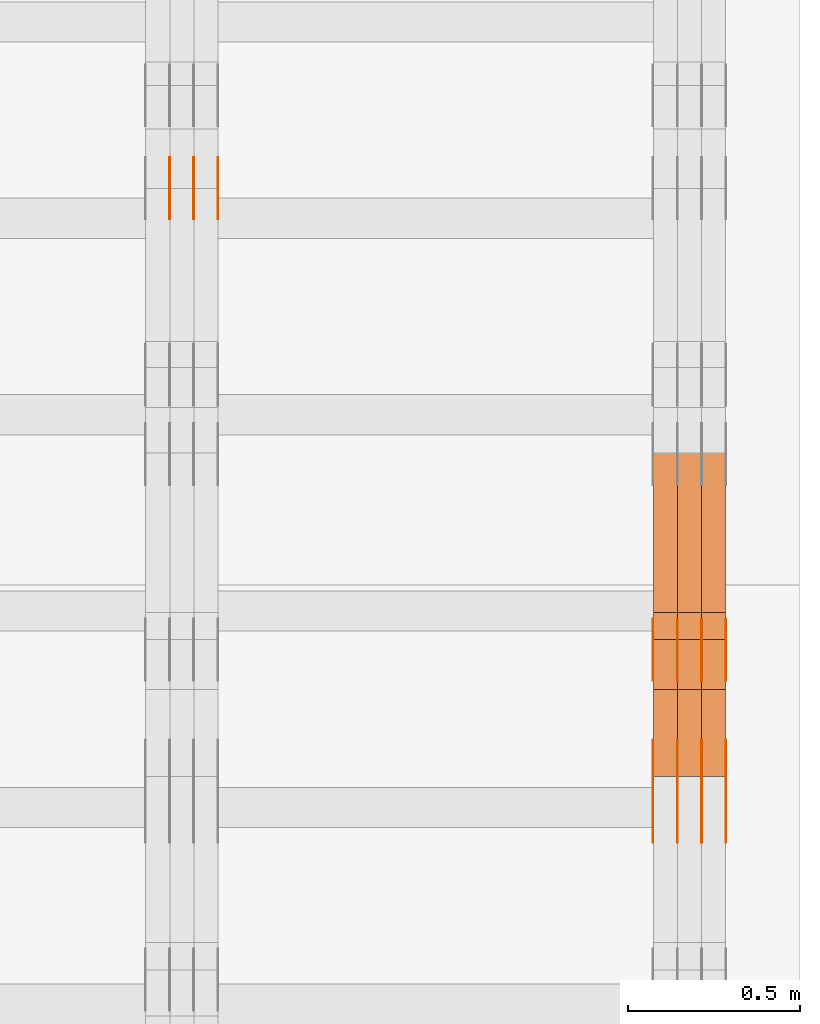
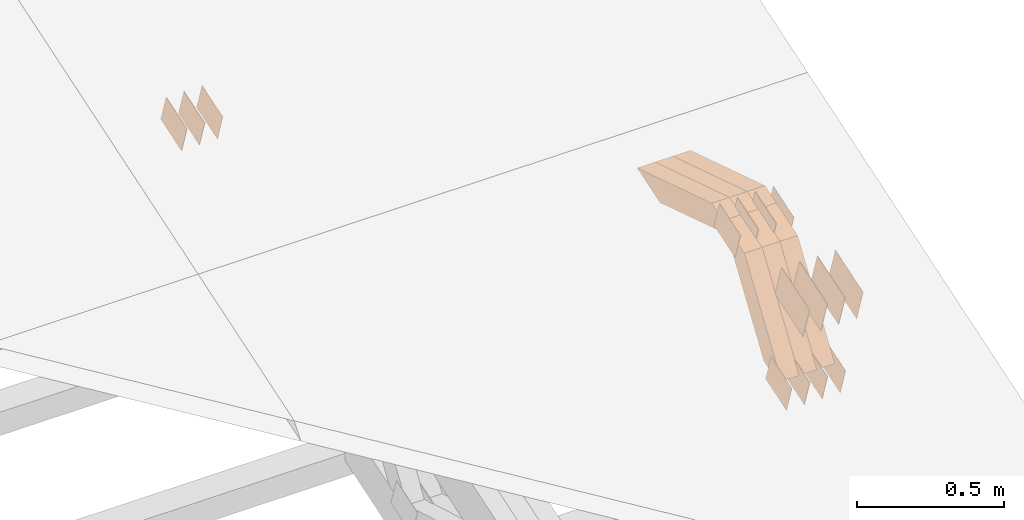
# One storey, part 310 of 385: 29 proxies.
"""IFC2X3 building model written with IfcOpenShell, lengths in millimetres."""

from ifc_helpers import new_model, entity, si_unit, converted_unit, derived_unit, direction, frame, origin, place, context, subcontext, project, spatial, polyline, outline, extrude, source, transform, mapped, material, type_object, type_shapes, element, save


model = new_model("IFC2X3")

# Units and contexts
model_context = context("Model", 3, precision=0.01, world=origin(), true_north=direction((6.12303176911189e-17, 1.0)))
body_context = subcontext(model_context, "Body", "Model", "MODEL_VIEW")
ifc_project = project(units=[si_unit("LENGTHUNIT", "METRE", prefix="MILLI"), si_unit("AREAUNIT", "SQUARE_METRE"), si_unit("VOLUMEUNIT", "CUBIC_METRE"), converted_unit("PLANEANGLEUNIT", "DEGREE", entity("IfcRatioMeasure", 0.0174532925199433), si_unit("PLANEANGLEUNIT", "RADIAN"), dimensions=[0, 0, 0, 0, 0, 0, 0]), si_unit("MASSUNIT", "GRAM", prefix="KILO"), derived_unit("MASSDENSITYUNIT", [(si_unit("MASSUNIT", "GRAM", prefix="KILO"), 1), (si_unit("LENGTHUNIT", "METRE"), -3)]), si_unit("TIMEUNIT", "SECOND"), si_unit("FREQUENCYUNIT", "HERTZ"), si_unit("THERMODYNAMICTEMPERATUREUNIT", "DEGREE_CELSIUS"), derived_unit("THERMALTRANSMITTANCEUNIT", [(si_unit("MASSUNIT", "GRAM", prefix="KILO"), 1), (si_unit("THERMODYNAMICTEMPERATUREUNIT", "KELVIN"), -1), (si_unit("TIMEUNIT", "SECOND"), -3)]), derived_unit("VOLUMETRICFLOWRATEUNIT", [(si_unit("LENGTHUNIT", "METRE"), 3), (si_unit("TIMEUNIT", "SECOND"), -1)]), si_unit("ELECTRICCURRENTUNIT", "AMPERE"), si_unit("ELECTRICVOLTAGEUNIT", "VOLT"), si_unit("POWERUNIT", "WATT"), si_unit("FORCEUNIT", "NEWTON", prefix="KILO"), si_unit("ILLUMINANCEUNIT", "LUX"), si_unit("LUMINOUSFLUXUNIT", "LUMEN"), si_unit("LUMINOUSINTENSITYUNIT", "CANDELA"), derived_unit("USERDEFINED", [(si_unit("MASSUNIT", "GRAM", prefix="KILO"), -1), (si_unit("LENGTHUNIT", "METRE"), -2), (si_unit("TIMEUNIT", "SECOND"), 3), (si_unit("LUMINOUSFLUXUNIT", "LUMEN"), 1)]), derived_unit("LINEARVELOCITYUNIT", [(si_unit("LENGTHUNIT", "METRE"), 1), (si_unit("TIMEUNIT", "SECOND"), -1)]), si_unit("PRESSUREUNIT", "PASCAL"), derived_unit("USERDEFINED", [(si_unit("LENGTHUNIT", "METRE"), -2), (si_unit("MASSUNIT", "GRAM", prefix="KILO"), 1), (si_unit("TIMEUNIT", "SECOND"), -2)])], contexts=[model_context])

# Site, building, storey
site_placement = place(None, origin())
site = spatial("IfcSite", under=ifc_project, at=site_placement, CompositionType="ELEMENT")
building_placement = place(site_placement, origin())
building = spatial("IfcBuilding", under=site, at=building_placement, CompositionType="ELEMENT")
storey_placement = place(building_placement, origin())
storey = spatial("IfcBuildingStorey", under=building, at=storey_placement, Name="Default", CompositionType="ELEMENT", Elevation=0.0)

# Proxies
ifc_material_1 = material(Name="IfcSurfaceStyle #614800")
building_element_proxy_type_1 = type_object("IfcBuildingElementProxyType", PredefinedType="NOTDEFINED", material=ifc_material_1)
shared_shape_1 = source(origin(), body_context, "Body", "SweptSolid", [
    extrude(outline(polyline([(-74.9998707133927, -60.0000596852269), (74.9998841352353, -60.0000596852269), (74.999861282944, 60.0000596852269), (-74.9998747047866, 60.0000596852269), (-74.9998707133927, -60.0000596852269)])), frame((74.9998841352353, 60.0000596852269, 0.0), z_axis=(0.0, 0.0, 1.0), x_axis=(-1.0, 0.0, 0.0)), (0.0, 0.0, 1.0), 1.3),
])
type_shapes(building_element_proxy_type_1, [shared_shape_1])
proxy_1_placement = place(building_placement, frame((49861.3, 5067.4882362875, 826.131473120182), z_axis=(-1.0, 0.0, 0.0), x_axis=(0.0, 0.951056516295124, 0.309016994375039)))
element("IfcBuildingElementProxy", 1, at=proxy_1_placement, inside=storey, type_object=building_element_proxy_type_1, material=ifc_material_1, context=body_context, shape_type="MappedRepresentation", body=[
    mapped(shared_shape_1, transform((0.0, 0.0, 0.0), scale=1.0)),
])
ifc_material_2 = material(Name="IfcSurfaceStyle #614743")
building_element_proxy_type_2 = type_object("IfcBuildingElementProxyType", PredefinedType="NOTDEFINED", material=ifc_material_2)
shared_shape_2 = source(origin(), body_context, "Body", "SweptSolid", [
    extrude(outline(polyline([(-74.9998707133927, -60.0000596852269), (74.9998841352353, -60.0000596852269), (74.999861282944, 60.0000596852269), (-74.9998747047866, 60.0000596852269), (-74.9998707133927, -60.0000596852269)])), frame((74.9998841352353, 60.0000596852269, 0.0), z_axis=(0.0, 0.0, 1.0), x_axis=(-1.0, 0.0, 0.0)), (0.0, 0.0, 1.0), 1.3),
])
type_shapes(building_element_proxy_type_2, [shared_shape_2])
proxy_2_placement = place(building_placement, frame((49790.0, 5067.4882362875, 826.131473120182), z_axis=(-1.0, 0.0, 0.0), x_axis=(0.0, 0.951056516295124, 0.309016994375039)))
element("IfcBuildingElementProxy", 2, at=proxy_2_placement, inside=storey, type_object=building_element_proxy_type_2, material=ifc_material_2, context=body_context, shape_type="MappedRepresentation", body=[
    mapped(shared_shape_2, transform((0.0, 0.0, 0.0), scale=1.0)),
])
ifc_material_3 = material(Name="IfcSurfaceStyle #614686")
building_element_proxy_type_3 = type_object("IfcBuildingElementProxyType", PredefinedType="NOTDEFINED", material=ifc_material_3)
shared_shape_3 = source(origin(), body_context, "Body", "SweptSolid", [
    extrude(outline(polyline([(-74.9998707133927, -60.0000596852269), (74.9998841352353, -60.0000596852269), (74.999861282944, 60.0000596852269), (-74.9998747047866, 60.0000596852269), (-74.9998707133927, -60.0000596852269)])), frame((74.9998841352353, 60.0000596852269, 0.0), z_axis=(0.0, 0.0, 1.0), x_axis=(-1.0, 0.0, 0.0)), (0.0, 0.0, 1.0), 1.3),
])
type_shapes(building_element_proxy_type_3, [shared_shape_3])
proxy_3_placement = place(building_placement, frame((49791.3, 5067.4882362875, 826.131473120182), z_axis=(-1.0, 0.0, 0.0), x_axis=(0.0, 0.951056516295124, 0.309016994375039)))
element("IfcBuildingElementProxy", 3, at=proxy_3_placement, inside=storey, type_object=building_element_proxy_type_3, material=ifc_material_3, context=body_context, shape_type="MappedRepresentation", body=[
    mapped(shared_shape_3, transform((0.0, 0.0, 0.0), scale=1.0)),
])
ifc_material_4 = material(Name="IfcSurfaceStyle #614629")
building_element_proxy_type_4 = type_object("IfcBuildingElementProxyType", PredefinedType="NOTDEFINED", material=ifc_material_4)
shared_shape_4 = source(origin(), body_context, "Body", "SweptSolid", [
    extrude(outline(polyline([(-74.9998707133927, -60.0000596852269), (74.9998841352353, -60.0000596852269), (74.999861282944, 60.0000596852269), (-74.9998747047866, 60.0000596852269), (-74.9998707133927, -60.0000596852269)])), frame((74.9998841352353, 60.0000596852269, 0.0), z_axis=(0.0, 0.0, 1.0), x_axis=(-1.0, 0.0, 0.0)), (0.0, 0.0, 1.0), 1.29999999999999),
])
type_shapes(building_element_proxy_type_4, [shared_shape_4])
proxy_4_placement = place(building_placement, frame((49720.0, 5067.4882362875, 826.131473120182), z_axis=(-1.0, 0.0, 0.0), x_axis=(0.0, 0.951056516295124, 0.309016994375039)))
element("IfcBuildingElementProxy", 4, at=proxy_4_placement, inside=storey, type_object=building_element_proxy_type_4, material=ifc_material_4, context=body_context, shape_type="MappedRepresentation", body=[
    mapped(shared_shape_4, transform((0.0, 0.0, 0.0), scale=1.0)),
])
ifc_material_5 = material(Name="IfcSurfaceStyle #614572")
building_element_proxy_type_5 = type_object("IfcBuildingElementProxyType", PredefinedType="NOTDEFINED", material=ifc_material_5)
shared_shape_5 = source(origin(), body_context, "Body", "SweptSolid", [
    extrude(outline(polyline([(-74.9998707133927, -60.0000596852269), (74.9998841352353, -60.0000596852269), (74.999861282944, 60.0000596852269), (-74.9998747047866, 60.0000596852269), (-74.9998707133927, -60.0000596852269)])), frame((74.9998841352353, 60.0000596852269, 0.0), z_axis=(0.0, 0.0, 1.0), x_axis=(-1.0, 0.0, 0.0)), (0.0, 0.0, 1.0), 1.29999999999999),
])
type_shapes(building_element_proxy_type_5, [shared_shape_5])
proxy_5_placement = place(building_placement, frame((49721.3, 5067.4882362875, 826.131473120182), z_axis=(-1.0, 0.0, 0.0), x_axis=(0.0, 0.951056516295124, 0.309016994375039)))
element("IfcBuildingElementProxy", 5, at=proxy_5_placement, inside=storey, type_object=building_element_proxy_type_5, material=ifc_material_5, context=body_context, shape_type="MappedRepresentation", body=[
    mapped(shared_shape_5, transform((0.0, 0.0, 0.0), scale=1.0)),
])
ifc_material_6 = material(Name="IfcSurfaceStyle #614515")
building_element_proxy_type_6 = type_object("IfcBuildingElementProxyType", PredefinedType="NOTDEFINED", material=ifc_material_6)
shared_shape_6 = source(origin(), body_context, "Body", "SweptSolid", [
    extrude(outline(polyline([(-74.9998707133927, -60.0000596852269), (74.9998841352353, -60.0000596852269), (74.999861282944, 60.0000596852269), (-74.9998747047866, 60.0000596852269), (-74.9998707133927, -60.0000596852269)])), frame((74.9998841352353, 60.0000596852269, 0.0), z_axis=(0.0, 0.0, 1.0), x_axis=(-1.0, 0.0, 0.0)), (0.0, 0.0, 1.0), 1.29999999999999),
])
type_shapes(building_element_proxy_type_6, [shared_shape_6])
proxy_6_placement = place(building_placement, frame((49650.0, 5067.4882362875, 826.131473120182), z_axis=(-1.0, 0.0, 0.0), x_axis=(0.0, 0.951056516295124, 0.309016994375039)))
element("IfcBuildingElementProxy", 6, at=proxy_6_placement, inside=storey, type_object=building_element_proxy_type_6, material=ifc_material_6, context=body_context, shape_type="MappedRepresentation", body=[
    mapped(shared_shape_6, transform((0.0, 0.0, 0.0), scale=1.0)),
])
ifc_material_7 = material(Name="IfcSurfaceStyle #608986")
building_element_proxy_type_7 = type_object("IfcBuildingElementProxyType", PredefinedType="NOTDEFINED", material=ifc_material_7)
shared_shape_7 = source(origin(), body_context, "Body", "SweptSolid", [
    extrude(outline(polyline([(-74.9998565677224, -60.0000596852342), (74.9998794200083, -60.0000596852342), (74.9998565677242, 60.0000596852342), (-74.9998794200101, 60.0000596852342), (-74.9998565677224, -60.0000596852342)])), frame((74.9998794200083, 60.0000596852342, 0.0), z_axis=(0.0, 0.0, 1.0), x_axis=(-1.0, 0.0, 0.0)), (0.0, 0.0, 1.0), 1.3),
])
type_shapes(building_element_proxy_type_7, [shared_shape_7])
proxy_7_placement = place(building_placement, frame((49861.3, 5418.6991737875, 1250.81341892098), z_axis=(-1.0, 0.0, 0.0), x_axis=(0.0, 0.951056516295154, 0.309016994374948)))
element("IfcBuildingElementProxy", 7, at=proxy_7_placement, inside=storey, type_object=building_element_proxy_type_7, material=ifc_material_7, context=body_context, shape_type="MappedRepresentation", body=[
    mapped(shared_shape_7, transform((0.0, 0.0, 0.0), scale=1.0)),
])
ifc_material_8 = material(Name="IfcSurfaceStyle #608929")
building_element_proxy_type_8 = type_object("IfcBuildingElementProxyType", PredefinedType="NOTDEFINED", material=ifc_material_8)
shared_shape_8 = source(origin(), body_context, "Body", "SweptSolid", [
    extrude(outline(polyline([(-74.9998565677224, -60.0000596852342), (74.9998794200083, -60.0000596852342), (74.9998565677242, 60.0000596852342), (-74.9998794200101, 60.0000596852342), (-74.9998565677224, -60.0000596852342)])), frame((74.9998794200083, 60.0000596852342, 0.0), z_axis=(0.0, 0.0, 1.0), x_axis=(-1.0, 0.0, 0.0)), (0.0, 0.0, 1.0), 1.3),
])
type_shapes(building_element_proxy_type_8, [shared_shape_8])
proxy_8_placement = place(building_placement, frame((49790.0, 5418.6991737875, 1250.81341892098), z_axis=(-1.0, 0.0, 0.0), x_axis=(0.0, 0.951056516295154, 0.309016994374948)))
element("IfcBuildingElementProxy", 8, at=proxy_8_placement, inside=storey, type_object=building_element_proxy_type_8, material=ifc_material_8, context=body_context, shape_type="MappedRepresentation", body=[
    mapped(shared_shape_8, transform((0.0, 0.0, 0.0), scale=1.0)),
])
ifc_material_9 = material(Name="IfcSurfaceStyle #608872")
building_element_proxy_type_9 = type_object("IfcBuildingElementProxyType", PredefinedType="NOTDEFINED", material=ifc_material_9)
shared_shape_9 = source(origin(), body_context, "Body", "SweptSolid", [
    extrude(outline(polyline([(-74.9998565677224, -60.0000596852342), (74.9998794200083, -60.0000596852342), (74.9998565677242, 60.0000596852342), (-74.9998794200101, 60.0000596852342), (-74.9998565677224, -60.0000596852342)])), frame((74.9998794200083, 60.0000596852342, 0.0), z_axis=(0.0, 0.0, 1.0), x_axis=(-1.0, 0.0, 0.0)), (0.0, 0.0, 1.0), 1.3),
])
type_shapes(building_element_proxy_type_9, [shared_shape_9])
proxy_9_placement = place(building_placement, frame((49791.3, 5418.6991737875, 1250.81341892098), z_axis=(-1.0, 0.0, 0.0), x_axis=(0.0, 0.951056516295154, 0.309016994374948)))
element("IfcBuildingElementProxy", 9, at=proxy_9_placement, inside=storey, type_object=building_element_proxy_type_9, material=ifc_material_9, context=body_context, shape_type="MappedRepresentation", body=[
    mapped(shared_shape_9, transform((0.0, 0.0, 0.0), scale=1.0)),
])
ifc_material_10 = material(Name="IfcSurfaceStyle #608815")
building_element_proxy_type_10 = type_object("IfcBuildingElementProxyType", PredefinedType="NOTDEFINED", material=ifc_material_10)
shared_shape_10 = source(origin(), body_context, "Body", "SweptSolid", [
    extrude(outline(polyline([(-74.9998565677224, -60.0000596852342), (74.9998794200083, -60.0000596852342), (74.9998565677242, 60.0000596852342), (-74.9998794200101, 60.0000596852342), (-74.9998565677224, -60.0000596852342)])), frame((74.9998794200083, 60.0000596852342, 0.0), z_axis=(0.0, 0.0, 1.0), x_axis=(-1.0, 0.0, 0.0)), (0.0, 0.0, 1.0), 1.29999999999999),
])
type_shapes(building_element_proxy_type_10, [shared_shape_10])
proxy_10_placement = place(building_placement, frame((49720.0, 5418.6991737875, 1250.81341892098), z_axis=(-1.0, 0.0, 0.0), x_axis=(0.0, 0.951056516295154, 0.309016994374948)))
element("IfcBuildingElementProxy", 10, at=proxy_10_placement, inside=storey, type_object=building_element_proxy_type_10, material=ifc_material_10, context=body_context, shape_type="MappedRepresentation", body=[
    mapped(shared_shape_10, transform((0.0, 0.0, 0.0), scale=1.0)),
])
ifc_material_11 = material(Name="IfcSurfaceStyle #608758")
building_element_proxy_type_11 = type_object("IfcBuildingElementProxyType", PredefinedType="NOTDEFINED", material=ifc_material_11)
shared_shape_11 = source(origin(), body_context, "Body", "SweptSolid", [
    extrude(outline(polyline([(-74.9998565677224, -60.0000596852342), (74.9998794200083, -60.0000596852342), (74.9998565677242, 60.0000596852342), (-74.9998794200101, 60.0000596852342), (-74.9998565677224, -60.0000596852342)])), frame((74.9998794200083, 60.0000596852342, 0.0), z_axis=(0.0, 0.0, 1.0), x_axis=(-1.0, 0.0, 0.0)), (0.0, 0.0, 1.0), 1.29999999999999),
])
type_shapes(building_element_proxy_type_11, [shared_shape_11])
proxy_11_placement = place(building_placement, frame((49721.3, 5418.6991737875, 1250.81341892098), z_axis=(-1.0, 0.0, 0.0), x_axis=(0.0, 0.951056516295154, 0.309016994374948)))
element("IfcBuildingElementProxy", 11, at=proxy_11_placement, inside=storey, type_object=building_element_proxy_type_11, material=ifc_material_11, context=body_context, shape_type="MappedRepresentation", body=[
    mapped(shared_shape_11, transform((0.0, 0.0, 0.0), scale=1.0)),
])
ifc_material_12 = material(Name="IfcSurfaceStyle #608701")
building_element_proxy_type_12 = type_object("IfcBuildingElementProxyType", PredefinedType="NOTDEFINED", material=ifc_material_12)
shared_shape_12 = source(origin(), body_context, "Body", "SweptSolid", [
    extrude(outline(polyline([(-74.9998565677224, -60.0000596852342), (74.9998794200083, -60.0000596852342), (74.9998565677242, 60.0000596852342), (-74.9998794200101, 60.0000596852342), (-74.9998565677224, -60.0000596852342)])), frame((74.9998794200083, 60.0000596852342, 0.0), z_axis=(0.0, 0.0, 1.0), x_axis=(-1.0, 0.0, 0.0)), (0.0, 0.0, 1.0), 1.29999999999999),
])
type_shapes(building_element_proxy_type_12, [shared_shape_12])
proxy_12_placement = place(building_placement, frame((49650.0, 5418.6991737875, 1250.81341892098), z_axis=(-1.0, 0.0, 0.0), x_axis=(0.0, 0.951056516295154, 0.309016994374948)))
element("IfcBuildingElementProxy", 12, at=proxy_12_placement, inside=storey, type_object=building_element_proxy_type_12, material=ifc_material_12, context=body_context, shape_type="MappedRepresentation", body=[
    mapped(shared_shape_12, transform((0.0, 0.0, 0.0), scale=1.0)),
])
ifc_material_13 = material(Name="IfcSurfaceStyle #605566")
building_element_proxy_type_13 = type_object("IfcBuildingElementProxyType", PredefinedType="NOTDEFINED", material=ifc_material_13)
shared_shape_13 = source(origin(), body_context, "Body", "SweptSolid", [
    extrude(outline(polyline([(-99.9996257846169, -71.999973710258), (100.000009625089, -71.999973710258), (99.9996257846187, 71.999973710258), (-100.000009625091, 71.999973710258), (-99.9996257846169, -71.999973710258)])), frame((100.000083496635, 72.0000008245779, 0.0), z_axis=(0.0, 0.0, 1.0), x_axis=(-1.0, 0.0, 0.0)), (0.0, 0.0, 1.0), 1.3),
])
type_shapes(building_element_proxy_type_13, [shared_shape_13])
proxy_13_placement = place(building_placement, frame((49861.3, 4947.73195917316, 1225.53937157357), z_axis=(-1.0, 0.0, 0.0), x_axis=(0.0, 0.951056516295154, 0.309016994374948)))
element("IfcBuildingElementProxy", 13, at=proxy_13_placement, inside=storey, type_object=building_element_proxy_type_13, material=ifc_material_13, context=body_context, shape_type="MappedRepresentation", body=[
    mapped(shared_shape_13, transform((0.0, 0.0, 0.0), scale=1.0)),
])
ifc_material_14 = material(Name="IfcSurfaceStyle #605509")
building_element_proxy_type_14 = type_object("IfcBuildingElementProxyType", PredefinedType="NOTDEFINED", material=ifc_material_14)
shared_shape_14 = source(origin(), body_context, "Body", "SweptSolid", [
    extrude(outline(polyline([(-99.9996257846169, -71.999973710258), (100.000009625089, -71.999973710258), (99.9996257846187, 71.999973710258), (-100.000009625091, 71.999973710258), (-99.9996257846169, -71.999973710258)])), frame((100.000083496635, 72.0000008245779, 0.0), z_axis=(0.0, 0.0, 1.0), x_axis=(-1.0, 0.0, 0.0)), (0.0, 0.0, 1.0), 1.3),
])
type_shapes(building_element_proxy_type_14, [shared_shape_14])
proxy_14_placement = place(building_placement, frame((49790.0, 4947.73195917316, 1225.53937157357), z_axis=(-1.0, 0.0, 0.0), x_axis=(0.0, 0.951056516295154, 0.309016994374948)))
element("IfcBuildingElementProxy", 14, at=proxy_14_placement, inside=storey, type_object=building_element_proxy_type_14, material=ifc_material_14, context=body_context, shape_type="MappedRepresentation", body=[
    mapped(shared_shape_14, transform((0.0, 0.0, 0.0), scale=1.0)),
])
ifc_material_15 = material(Name="IfcSurfaceStyle #605452")
building_element_proxy_type_15 = type_object("IfcBuildingElementProxyType", PredefinedType="NOTDEFINED", material=ifc_material_15)
shared_shape_15 = source(origin(), body_context, "Body", "SweptSolid", [
    extrude(outline(polyline([(-99.9996257846169, -71.999973710258), (100.000009625089, -71.999973710258), (99.9996257846187, 71.999973710258), (-100.000009625091, 71.999973710258), (-99.9996257846169, -71.999973710258)])), frame((100.000083496635, 72.0000008245779, 0.0), z_axis=(0.0, 0.0, 1.0), x_axis=(-1.0, 0.0, 0.0)), (0.0, 0.0, 1.0), 1.3),
])
type_shapes(building_element_proxy_type_15, [shared_shape_15])
proxy_15_placement = place(building_placement, frame((49791.3, 4947.73195917316, 1225.53937157357), z_axis=(-1.0, 0.0, 0.0), x_axis=(0.0, 0.951056516295154, 0.309016994374948)))
element("IfcBuildingElementProxy", 15, at=proxy_15_placement, inside=storey, type_object=building_element_proxy_type_15, material=ifc_material_15, context=body_context, shape_type="MappedRepresentation", body=[
    mapped(shared_shape_15, transform((0.0, 0.0, 0.0), scale=1.0)),
])
ifc_material_16 = material(Name="IfcSurfaceStyle #605395")
building_element_proxy_type_16 = type_object("IfcBuildingElementProxyType", PredefinedType="NOTDEFINED", material=ifc_material_16)
shared_shape_16 = source(origin(), body_context, "Body", "SweptSolid", [
    extrude(outline(polyline([(-99.9996257846169, -71.999973710258), (100.000009625089, -71.999973710258), (99.9996257846187, 71.999973710258), (-100.000009625091, 71.999973710258), (-99.9996257846169, -71.999973710258)])), frame((100.000083496635, 72.0000008245779, 0.0), z_axis=(0.0, 0.0, 1.0), x_axis=(-1.0, 0.0, 0.0)), (0.0, 0.0, 1.0), 1.29999999999998),
])
type_shapes(building_element_proxy_type_16, [shared_shape_16])
proxy_16_placement = place(building_placement, frame((49720.0, 4947.73195917316, 1225.53937157357), z_axis=(-1.0, 0.0, 0.0), x_axis=(0.0, 0.951056516295154, 0.309016994374948)))
element("IfcBuildingElementProxy", 16, at=proxy_16_placement, inside=storey, type_object=building_element_proxy_type_16, material=ifc_material_16, context=body_context, shape_type="MappedRepresentation", body=[
    mapped(shared_shape_16, transform((0.0, 0.0, 0.0), scale=1.0)),
])
ifc_material_17 = material(Name="IfcSurfaceStyle #605338")
building_element_proxy_type_17 = type_object("IfcBuildingElementProxyType", PredefinedType="NOTDEFINED", material=ifc_material_17)
shared_shape_17 = source(origin(), body_context, "Body", "SweptSolid", [
    extrude(outline(polyline([(-99.9996257846169, -71.999973710258), (100.000009625089, -71.999973710258), (99.9996257846187, 71.999973710258), (-100.000009625091, 71.999973710258), (-99.9996257846169, -71.999973710258)])), frame((100.000083496635, 72.0000008245779, 0.0), z_axis=(0.0, 0.0, 1.0), x_axis=(-1.0, 0.0, 0.0)), (0.0, 0.0, 1.0), 1.29999999999998),
])
type_shapes(building_element_proxy_type_17, [shared_shape_17])
proxy_17_placement = place(building_placement, frame((49721.3, 4947.73195917316, 1225.53937157357), z_axis=(-1.0, 0.0, 0.0), x_axis=(0.0, 0.951056516295154, 0.309016994374948)))
element("IfcBuildingElementProxy", 17, at=proxy_17_placement, inside=storey, type_object=building_element_proxy_type_17, material=ifc_material_17, context=body_context, shape_type="MappedRepresentation", body=[
    mapped(shared_shape_17, transform((0.0, 0.0, 0.0), scale=1.0)),
])
ifc_material_18 = material(Name="IfcSurfaceStyle #605281")
building_element_proxy_type_18 = type_object("IfcBuildingElementProxyType", PredefinedType="NOTDEFINED", material=ifc_material_18)
shared_shape_18 = source(origin(), body_context, "Body", "SweptSolid", [
    extrude(outline(polyline([(-99.9996257846169, -71.999973710258), (100.000009625089, -71.999973710258), (99.9996257846187, 71.999973710258), (-100.000009625091, 71.999973710258), (-99.9996257846169, -71.999973710258)])), frame((100.000083496635, 72.0000008245779, 0.0), z_axis=(0.0, 0.0, 1.0), x_axis=(-1.0, 0.0, 0.0)), (0.0, 0.0, 1.0), 1.29999999999999),
])
type_shapes(building_element_proxy_type_18, [shared_shape_18])
proxy_18_placement = place(building_placement, frame((49650.0, 4947.73195917316, 1225.53937157357), z_axis=(-1.0, 0.0, 0.0), x_axis=(0.0, 0.951056516295154, 0.309016994374948)))
element("IfcBuildingElementProxy", 18, at=proxy_18_placement, inside=storey, type_object=building_element_proxy_type_18, material=ifc_material_18, context=body_context, shape_type="MappedRepresentation", body=[
    mapped(shared_shape_18, transform((0.0, 0.0, 0.0), scale=1.0)),
])
ifc_material_19 = material(Name="IfcSurfaceStyle #596224")
building_element_proxy_type_19 = type_object("IfcBuildingElementProxyType", Name="T2-W15 596222", PredefinedType="NOTDEFINED", material=ifc_material_19)
shared_shape_19 = source(origin(), body_context, "Body", "SweptSolid", [
    extrude(outline(polyline([(-243.398341390642, -47.5000170814535), (237.775741169608, -47.5000170814535), (224.054017709933, 0.000127777485579883), (157.692261395711, 47.4999531927108), (-376.12367888461, 47.4999531927107), (-243.398341390642, -47.5000170814535)])), frame((237.77637044506, 47.5003404768297, 0.0), z_axis=(0.0, 0.0, 1.0), x_axis=(-1.0, 0.0, 0.0)), (0.0, 0.0, 1.0), 70.0),
])
type_shapes(building_element_proxy_type_19, [shared_shape_19])
proxy_19_placement = place(building_placement, frame((49860.0, 5540.23242178142, 1288.84274826279), z_axis=(-1.0, 0.0, 0.0), x_axis=(0.0, 0.95322291386448, -0.302268219440466)))
element("IfcBuildingElementProxy", 19, at=proxy_19_placement, inside=storey, type_object=building_element_proxy_type_19, material=ifc_material_19, Name="T2-W15", context=body_context, shape_type="MappedRepresentation", body=[
    mapped(shared_shape_19, transform((0.0, 0.0, 0.0), scale=1.0)),
])
ifc_material_20 = material(Name="IfcSurfaceStyle #596158")
building_element_proxy_type_20 = type_object("IfcBuildingElementProxyType", Name="T2-W15 596156", PredefinedType="NOTDEFINED", material=ifc_material_20)
shared_shape_20 = source(origin(), body_context, "Body", "SweptSolid", [
    extrude(outline(polyline([(-243.398341390642, -47.5000170814535), (237.775741169608, -47.5000170814535), (224.054017709933, 0.000127777485579883), (157.692261395711, 47.4999531927108), (-376.12367888461, 47.4999531927107), (-243.398341390642, -47.5000170814535)])), frame((237.77637044506, 47.5003404768297, 0.0), z_axis=(0.0, 0.0, 1.0), x_axis=(-1.0, 0.0, 0.0)), (0.0, 0.0, 1.0), 70.0),
])
type_shapes(building_element_proxy_type_20, [shared_shape_20])
proxy_20_placement = place(building_placement, frame((49790.0, 5540.23242178142, 1288.84274826279), z_axis=(-1.0, 0.0, 0.0), x_axis=(0.0, 0.95322291386448, -0.302268219440466)))
element("IfcBuildingElementProxy", 20, at=proxy_20_placement, inside=storey, type_object=building_element_proxy_type_20, material=ifc_material_20, Name="T2-W15", context=body_context, shape_type="MappedRepresentation", body=[
    mapped(shared_shape_20, transform((0.0, 0.0, 0.0), scale=1.0)),
])
ifc_material_21 = material(Name="IfcSurfaceStyle #596092")
building_element_proxy_type_21 = type_object("IfcBuildingElementProxyType", Name="T2-W15 596090", PredefinedType="NOTDEFINED", material=ifc_material_21)
shared_shape_21 = source(origin(), body_context, "Body", "SweptSolid", [
    extrude(outline(polyline([(-243.398341390642, -47.5000170814535), (237.775741169608, -47.5000170814535), (224.054017709933, 0.000127777485579883), (157.692261395711, 47.4999531927108), (-376.12367888461, 47.4999531927107), (-243.398341390642, -47.5000170814535)])), frame((237.77637044506, 47.5003404768297, 0.0), z_axis=(0.0, 0.0, 1.0), x_axis=(-1.0, 0.0, 0.0)), (0.0, 0.0, 1.0), 70.0),
])
type_shapes(building_element_proxy_type_21, [shared_shape_21])
proxy_21_placement = place(building_placement, frame((49720.0, 5540.23242178142, 1288.84274826279), z_axis=(-1.0, 0.0, 0.0), x_axis=(0.0, 0.95322291386448, -0.302268219440466)))
element("IfcBuildingElementProxy", 21, at=proxy_21_placement, inside=storey, type_object=building_element_proxy_type_21, material=ifc_material_21, Name="T2-W15", context=body_context, shape_type="MappedRepresentation", body=[
    mapped(shared_shape_21, transform((0.0, 0.0, 0.0), scale=1.0)),
])
ifc_material_22 = material(Name="IfcSurfaceStyle #595828")
building_element_proxy_type_22 = type_object("IfcBuildingElementProxyType", Name="T2-W22 595826", PredefinedType="NOTDEFINED", material=ifc_material_22)
shared_shape_22 = source(origin(), body_context, "Body", "SweptSolid", [
    extrude(outline(polyline([(-351.940486061686, -47.5005995570677), (149.451602529695, -47.5005995570676), (209.614029773051, 0.000108554198836676), (224.491670779786, 47.5010029530092), (-231.616817020846, 47.5000876069273), (-351.940486061686, -47.5005995570677)])), frame((224.491766107217, 47.5005524294596, 0.0), z_axis=(0.0, 0.0, 1.0), x_axis=(-1.0, 2.00686044286885e-06, 0.0)), (0.0, 0.0, 1.0), 70.0),
])
type_shapes(building_element_proxy_type_22, [shared_shape_22])
proxy_22_placement = place(building_placement, frame((49860.0, 5140.03125, 812.615600585936), z_axis=(-1.0, 0.0, 0.0), x_axis=(0.0, 0.554956576676696, 0.831879316970486)))
element("IfcBuildingElementProxy", 22, at=proxy_22_placement, inside=storey, type_object=building_element_proxy_type_22, material=ifc_material_22, Name="T2-W22", context=body_context, shape_type="MappedRepresentation", body=[
    mapped(shared_shape_22, transform((0.0, 0.0, 0.0), scale=1.0)),
])
ifc_material_23 = material(Name="IfcSurfaceStyle #595762")
building_element_proxy_type_23 = type_object("IfcBuildingElementProxyType", Name="T2-W22 595760", PredefinedType="NOTDEFINED", material=ifc_material_23)
shared_shape_23 = source(origin(), body_context, "Body", "SweptSolid", [
    extrude(outline(polyline([(-351.940486061686, -47.5005995570677), (149.451602529695, -47.5005995570676), (209.614029773051, 0.000108554198836676), (224.491670779786, 47.5010029530092), (-231.616817020846, 47.5000876069273), (-351.940486061686, -47.5005995570677)])), frame((224.491766107217, 47.5005524294596, 0.0), z_axis=(0.0, 0.0, 1.0), x_axis=(-1.0, 2.00686044286885e-06, 0.0)), (0.0, 0.0, 1.0), 70.0),
])
type_shapes(building_element_proxy_type_23, [shared_shape_23])
proxy_23_placement = place(building_placement, frame((49790.0, 5140.03125, 812.615600585936), z_axis=(-1.0, 0.0, 0.0), x_axis=(0.0, 0.554956576676696, 0.831879316970486)))
element("IfcBuildingElementProxy", 23, at=proxy_23_placement, inside=storey, type_object=building_element_proxy_type_23, material=ifc_material_23, Name="T2-W22", context=body_context, shape_type="MappedRepresentation", body=[
    mapped(shared_shape_23, transform((0.0, 0.0, 0.0), scale=1.0)),
])
ifc_material_24 = material(Name="IfcSurfaceStyle #595696")
building_element_proxy_type_24 = type_object("IfcBuildingElementProxyType", Name="T2-W22 595694", PredefinedType="NOTDEFINED", material=ifc_material_24)
shared_shape_24 = source(origin(), body_context, "Body", "SweptSolid", [
    extrude(outline(polyline([(-351.940486061686, -47.5005995570677), (149.451602529695, -47.5005995570676), (209.614029773051, 0.000108554198836676), (224.491670779786, 47.5010029530092), (-231.616817020846, 47.5000876069273), (-351.940486061686, -47.5005995570677)])), frame((224.491766107217, 47.5005524294596, 0.0), z_axis=(0.0, 0.0, 1.0), x_axis=(-1.0, 2.00686044286885e-06, 0.0)), (0.0, 0.0, 1.0), 70.0),
])
type_shapes(building_element_proxy_type_24, [shared_shape_24])
proxy_24_placement = place(building_placement, frame((49720.0, 5140.03125, 812.615600585936), z_axis=(-1.0, 0.0, 0.0), x_axis=(0.0, 0.554956576676696, 0.831879316970486)))
element("IfcBuildingElementProxy", 24, at=proxy_24_placement, inside=storey, type_object=building_element_proxy_type_24, material=ifc_material_24, Name="T2-W22", context=body_context, shape_type="MappedRepresentation", body=[
    mapped(shared_shape_24, transform((0.0, 0.0, 0.0), scale=1.0)),
])
ifc_material_25 = material(Name="IfcSurfaceStyle #586182")
building_element_proxy_type_25 = type_object("IfcBuildingElementProxyType", PredefinedType="NOTDEFINED", material=ifc_material_25)
shared_shape_25 = source(origin(), body_context, "Body", "SweptSolid", [
    extrude(outline(polyline([(-74.9998754286198, -60.0000016373433), (74.9998605591145, -60.0000016373433), (74.999875428618, 60.0000016373433), (-74.9998605591127, 60.0000016373433), (-74.9998754286198, -60.0000016373433)])), frame((75.0007059026038, 60.000210935219, 0.0), z_axis=(0.0, 0.0, 1.0), x_axis=(-1.0, 0.0, 0.0)), (0.0, 0.0, 1.0), 1.3),
])
type_shapes(building_element_proxy_type_25, [shared_shape_25])
proxy_25_placement = place(building_placement, frame((48386.3, 6760.15341914203, 1372.60670336718), z_axis=(-1.0, 0.0, 0.0), x_axis=(0.0, 0.951056516295124, 0.309016994375039)))
element("IfcBuildingElementProxy", 25, at=proxy_25_placement, inside=storey, type_object=building_element_proxy_type_25, material=ifc_material_25, context=body_context, shape_type="MappedRepresentation", body=[
    mapped(shared_shape_25, transform((0.0, 0.0, 0.0), scale=1.0)),
])
ifc_material_26 = material(Name="IfcSurfaceStyle #586125")
building_element_proxy_type_26 = type_object("IfcBuildingElementProxyType", PredefinedType="NOTDEFINED", material=ifc_material_26)
shared_shape_26 = source(origin(), body_context, "Body", "SweptSolid", [
    extrude(outline(polyline([(-74.9998754286198, -60.0000016373433), (74.9998605591145, -60.0000016373433), (74.999875428618, 60.0000016373433), (-74.9998605591127, 60.0000016373433), (-74.9998754286198, -60.0000016373433)])), frame((75.0007059026038, 60.000210935219, 0.0), z_axis=(0.0, 0.0, 1.0), x_axis=(-1.0, 0.0, 0.0)), (0.0, 0.0, 1.0), 1.3),
])
type_shapes(building_element_proxy_type_26, [shared_shape_26])
proxy_26_placement = place(building_placement, frame((48315.0, 6760.15341914203, 1372.60670336718), z_axis=(-1.0, 0.0, 0.0), x_axis=(0.0, 0.951056516295124, 0.309016994375039)))
element("IfcBuildingElementProxy", 26, at=proxy_26_placement, inside=storey, type_object=building_element_proxy_type_26, material=ifc_material_26, context=body_context, shape_type="MappedRepresentation", body=[
    mapped(shared_shape_26, transform((0.0, 0.0, 0.0), scale=1.0)),
])
ifc_material_27 = material(Name="IfcSurfaceStyle #586068")
building_element_proxy_type_27 = type_object("IfcBuildingElementProxyType", PredefinedType="NOTDEFINED", material=ifc_material_27)
shared_shape_27 = source(origin(), body_context, "Body", "SweptSolid", [
    extrude(outline(polyline([(-74.9998754286198, -60.0000016373433), (74.9998605591145, -60.0000016373433), (74.999875428618, 60.0000016373433), (-74.9998605591127, 60.0000016373433), (-74.9998754286198, -60.0000016373433)])), frame((75.0007059026038, 60.000210935219, 0.0), z_axis=(0.0, 0.0, 1.0), x_axis=(-1.0, 0.0, 0.0)), (0.0, 0.0, 1.0), 1.3),
])
type_shapes(building_element_proxy_type_27, [shared_shape_27])
proxy_27_placement = place(building_placement, frame((48316.3, 6760.15341914203, 1372.60670336718), z_axis=(-1.0, 0.0, 0.0), x_axis=(0.0, 0.951056516295124, 0.309016994375039)))
element("IfcBuildingElementProxy", 27, at=proxy_27_placement, inside=storey, type_object=building_element_proxy_type_27, material=ifc_material_27, context=body_context, shape_type="MappedRepresentation", body=[
    mapped(shared_shape_27, transform((0.0, 0.0, 0.0), scale=1.0)),
])
ifc_material_28 = material(Name="IfcSurfaceStyle #586011")
building_element_proxy_type_28 = type_object("IfcBuildingElementProxyType", PredefinedType="NOTDEFINED", material=ifc_material_28)
shared_shape_28 = source(origin(), body_context, "Body", "SweptSolid", [
    extrude(outline(polyline([(-74.9998754286198, -60.0000016373433), (74.9998605591145, -60.0000016373433), (74.999875428618, 60.0000016373433), (-74.9998605591127, 60.0000016373433), (-74.9998754286198, -60.0000016373433)])), frame((75.0007059026038, 60.000210935219, 0.0), z_axis=(0.0, 0.0, 1.0), x_axis=(-1.0, 0.0, 0.0)), (0.0, 0.0, 1.0), 1.29999999999999),
])
type_shapes(building_element_proxy_type_28, [shared_shape_28])
proxy_28_placement = place(building_placement, frame((48245.0, 6760.15341914203, 1372.60670336718), z_axis=(-1.0, 0.0, 0.0), x_axis=(0.0, 0.951056516295124, 0.309016994375039)))
element("IfcBuildingElementProxy", 28, at=proxy_28_placement, inside=storey, type_object=building_element_proxy_type_28, material=ifc_material_28, context=body_context, shape_type="MappedRepresentation", body=[
    mapped(shared_shape_28, transform((0.0, 0.0, 0.0), scale=1.0)),
])
ifc_material_29 = material(Name="IfcSurfaceStyle #585954")
building_element_proxy_type_29 = type_object("IfcBuildingElementProxyType", PredefinedType="NOTDEFINED", material=ifc_material_29)
shared_shape_29 = source(origin(), body_context, "Body", "SweptSolid", [
    extrude(outline(polyline([(-74.9998754286198, -60.0000016373433), (74.9998605591145, -60.0000016373433), (74.999875428618, 60.0000016373433), (-74.9998605591127, 60.0000016373433), (-74.9998754286198, -60.0000016373433)])), frame((75.0007059026038, 60.000210935219, 0.0), z_axis=(0.0, 0.0, 1.0), x_axis=(-1.0, 0.0, 0.0)), (0.0, 0.0, 1.0), 1.29999999999999),
])
type_shapes(building_element_proxy_type_29, [shared_shape_29])
proxy_29_placement = place(building_placement, frame((48246.3, 6760.15341914203, 1372.60670336718), z_axis=(-1.0, 0.0, 0.0), x_axis=(0.0, 0.951056516295124, 0.309016994375039)))
element("IfcBuildingElementProxy", 29, at=proxy_29_placement, inside=storey, type_object=building_element_proxy_type_29, material=ifc_material_29, context=body_context, shape_type="MappedRepresentation", body=[
    mapped(shared_shape_29, transform((0.0, 0.0, 0.0), scale=1.0)),
])

save(model, "model.ifc")
